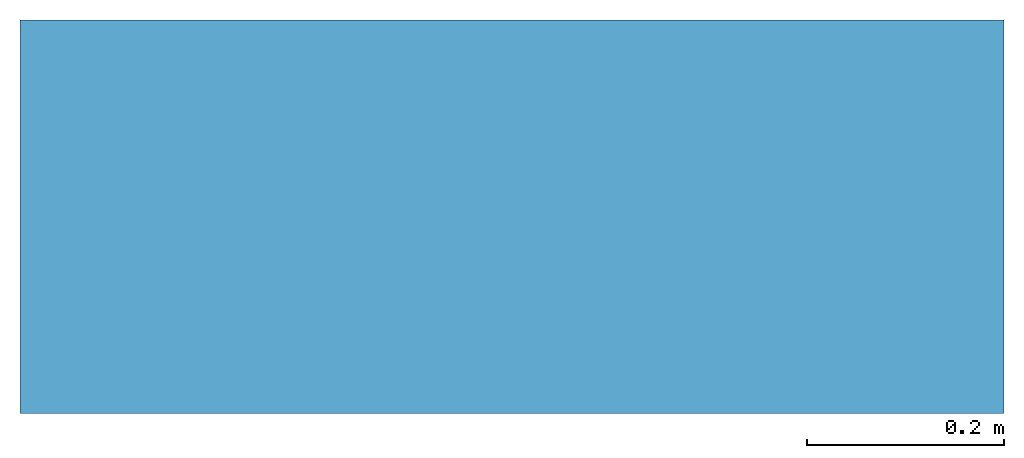
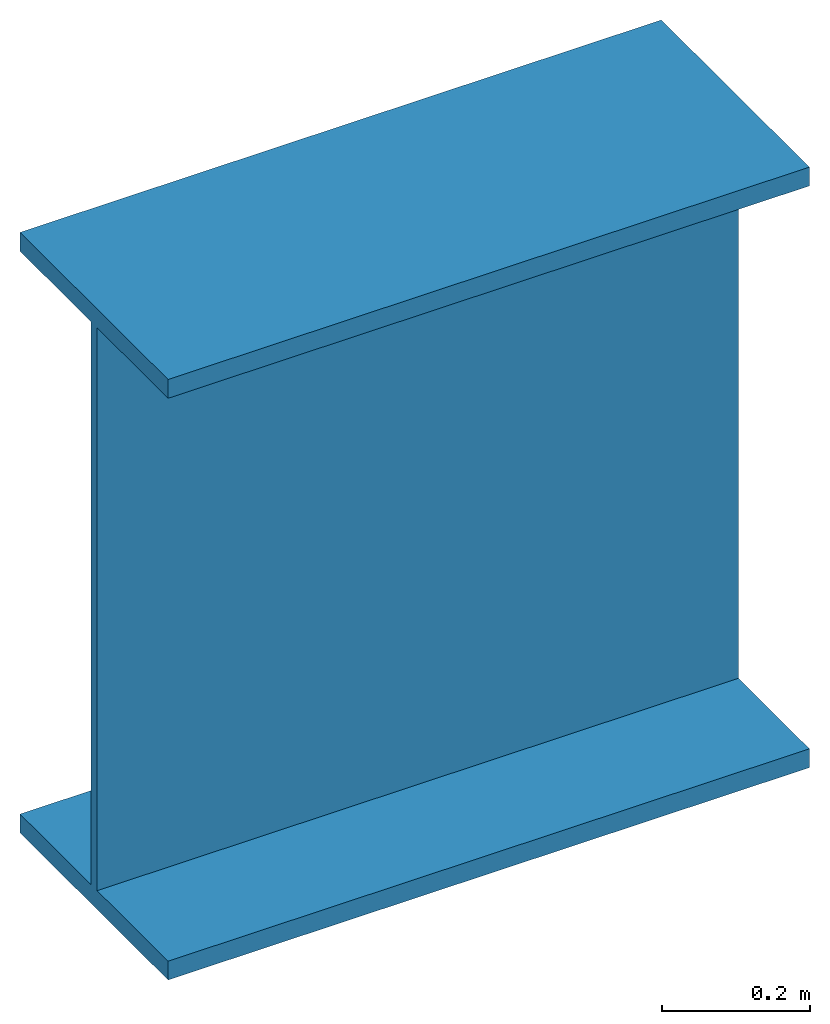
# Not in any storey: 1 beam.
"""IFC4 model written with IfcOpenShell, lengths in metres."""

from ifc_helpers import new_model, entity, si_unit, converted_unit, derived_unit, direction, frame, frame_2d, origin, place, context, subcontext, project, spatial, polyline, segment, composite_curve, i_section, outline, extrude, source, transform, mapped, material, material_profile, profile_set, profile_usage, type_object, type_shapes, element, save


model = new_model("IFC4")

# Units and contexts
model_context = context("Model", 3, precision=1e-05, world=origin(), true_north=direction((6.12303176911189e-17, 1.0)))
body_context = subcontext(model_context, "Body", "Model", "MODEL_VIEW")
ifc_project = project(units=[si_unit("LENGTHUNIT", "METRE"), si_unit("AREAUNIT", "SQUARE_METRE"), si_unit("VOLUMEUNIT", "CUBIC_METRE"), converted_unit("PLANEANGLEUNIT", "DEGREE", entity("IfcRatioMeasure", 0.0174532925199433), si_unit("PLANEANGLEUNIT", "RADIAN"), dimensions=[0, 0, 0, 0, 0, 0, 0]), si_unit("MASSUNIT", "GRAM", prefix="KILO"), derived_unit("MASSDENSITYUNIT", [(si_unit("MASSUNIT", "GRAM", prefix="KILO"), 1), (si_unit("LENGTHUNIT", "METRE"), -3)]), derived_unit("MOMENTOFINERTIAUNIT", [(si_unit("LENGTHUNIT", "METRE"), 4)]), si_unit("TIMEUNIT", "SECOND"), si_unit("FREQUENCYUNIT", "HERTZ"), si_unit("THERMODYNAMICTEMPERATUREUNIT", "DEGREE_CELSIUS"), derived_unit("THERMALTRANSMITTANCEUNIT", [(si_unit("MASSUNIT", "GRAM", prefix="KILO"), 1), (si_unit("THERMODYNAMICTEMPERATUREUNIT", "KELVIN"), -1), (si_unit("TIMEUNIT", "SECOND"), -3)]), derived_unit("VOLUMETRICFLOWRATEUNIT", [(si_unit("LENGTHUNIT", "METRE"), 3), (si_unit("TIMEUNIT", "SECOND"), -1)]), si_unit("ELECTRICCURRENTUNIT", "AMPERE"), si_unit("ELECTRICVOLTAGEUNIT", "VOLT"), si_unit("POWERUNIT", "WATT"), si_unit("FORCEUNIT", "NEWTON", prefix="KILO"), si_unit("ILLUMINANCEUNIT", "LUX"), si_unit("LUMINOUSFLUXUNIT", "LUMEN"), si_unit("LUMINOUSINTENSITYUNIT", "CANDELA"), derived_unit("USERDEFINED", [(si_unit("MASSUNIT", "GRAM", prefix="KILO"), -1), (si_unit("LENGTHUNIT", "METRE"), -2), (si_unit("TIMEUNIT", "SECOND"), 3), (si_unit("LUMINOUSFLUXUNIT", "LUMEN"), 1)]), derived_unit("LINEARVELOCITYUNIT", [(si_unit("LENGTHUNIT", "METRE"), 1), (si_unit("TIMEUNIT", "SECOND"), -1)]), si_unit("PRESSUREUNIT", "PASCAL"), derived_unit("USERDEFINED", [(si_unit("LENGTHUNIT", "METRE"), -2), (si_unit("MASSUNIT", "GRAM", prefix="KILO"), 1), (si_unit("TIMEUNIT", "SECOND"), -2)]), derived_unit("LINEARFORCEUNIT", [(si_unit("MASSUNIT", "GRAM", prefix="KILO"), 1), (si_unit("LENGTHUNIT", "METRE"), 1), (si_unit("TIMEUNIT", "SECOND"), -2), (si_unit("LENGTHUNIT", "METRE"), -1)]), derived_unit("PLANARFORCEUNIT", [(si_unit("MASSUNIT", "GRAM", prefix="KILO"), 1), (si_unit("LENGTHUNIT", "METRE"), 1), (si_unit("TIMEUNIT", "SECOND"), -2), (si_unit("LENGTHUNIT", "METRE"), -2)])], contexts=[model_context])

# Site
site_placement = place(None, origin())
site = spatial("IfcSite", under=ifc_project, at=site_placement, CompositionType="ELEMENT")

# Beam
ifc_material = material()
ifc_material_profile_1 = material_profile(ifc_material, outline(composite_curve([segment(polyline([(-0.200000000000002, -0.0309999999999954, 0.0), (-0.200000000000002, 0.0, 0.0)]), True, "CONTINUOUS"), segment(polyline([(-0.200000000000002, 0.0, 0.0), (0.199999999999997, 0.0, 0.0)]), True, "CONTINUOUS"), segment(polyline([(0.199999999999997, 0.0, 0.0), (0.199999999999997, -0.0309999999999949, 0.0)]), True, "CONTINUOUS"), segment(polyline([(0.199999999999997, -0.0309999999999949, 0.0), (0.00829999999999602, -0.0309999999999948, 0.0)]), True, "CONTINUOUS"), segment(polyline([(0.00829999999999602, -0.0309999999999948, 0.0), (0.00829999999999602, -0.958999999999991, 0.0)]), True, "CONTINUOUS"), segment(polyline([(0.00829999999999602, -0.958999999999991, 0.0), (0.199999999999994, -0.958999999999991, 0.0)]), True, "CONTINUOUS"), segment(polyline([(0.199999999999994, -0.958999999999991, 0.0), (0.199999999999994, -0.989999999999996, 0.0)]), True, "CONTINUOUS"), segment(polyline([(0.199999999999994, -0.989999999999996, 0.0), (-0.200000000000005, -0.989999999999996, 0.0)]), True, "CONTINUOUS"), segment(polyline([(-0.200000000000005, -0.989999999999996, 0.0), (-0.200000000000005, -0.958999999999996, 0.0)]), True, "CONTINUOUS"), segment(polyline([(-0.200000000000005, -0.958999999999996, 0.0), (-0.00830000000000258, -0.958999999999996, 0.0)]), True, "CONTINUOUS"), segment(polyline([(-0.00830000000000258, -0.958999999999996, 0.0), (-0.00830000000000258, -0.0309999999999954, 0.0)]), True, "CONTINUOUS"), segment(polyline([(-0.00830000000000258, -0.0309999999999954, 0.0), (-0.200000000000002, -0.0309999999999954, 0.0)]), True, "CONTINUOUS")], self_intersect=False), kind="CURVE"), Name="HL 1000A")
ifc_material_profile_2 = material_profile(ifc_material, outline(composite_curve([segment(polyline([(0.5, -0.200000000000002, 0.0), (0.5, -0.200000000000002, -0.0309999999999954)]), True, "CONTINUOUS"), segment(polyline([(0.5, -0.200000000000002, -0.0309999999999954), (0.5, -0.00830000000000231, -0.0309999999999954)]), True, "CONTINUOUS"), segment(polyline([(0.5, -0.00830000000000231, -0.0309999999999954), (0.5, -0.00830000000000231, -0.958999999999996)]), True, "CONTINUOUS"), segment(polyline([(0.5, -0.00830000000000231, -0.958999999999996), (0.5, -0.200000000000004, -0.958999999999996)]), True, "CONTINUOUS"), segment(polyline([(0.5, -0.200000000000004, -0.958999999999996), (0.5, -0.200000000000004, -0.989999999999996)]), True, "CONTINUOUS"), segment(polyline([(0.5, -0.200000000000004, -0.989999999999996), (0.5, 0.199999999999994, -0.989999999999996)]), True, "CONTINUOUS"), segment(polyline([(0.5, 0.199999999999994, -0.989999999999996), (0.5, 0.199999999999994, -0.958999999999991)]), True, "CONTINUOUS"), segment(polyline([(0.5, 0.199999999999994, -0.958999999999991), (0.5, 0.00829999999999629, -0.958999999999991)]), True, "CONTINUOUS"), segment(polyline([(0.5, 0.00829999999999629, -0.958999999999991), (0.5, 0.00829999999999629, -0.0309999999999948)]), True, "CONTINUOUS"), segment(polyline([(0.5, 0.00829999999999629, -0.0309999999999948), (0.5, 0.199999999999998, -0.0309999999999949)]), True, "CONTINUOUS"), segment(polyline([(0.5, 0.199999999999998, -0.0309999999999949), (0.5, 0.199999999999998, 0.0)]), True, "CONTINUOUS"), segment(polyline([(0.5, 0.199999999999998, 0.0), (0.5, -0.200000000000002, 0.0)]), True, "CONTINUOUS")], self_intersect=False), kind="CURVE"), Name="HL 1000A")
ifc_profile_set = profile_set([ifc_material_profile_1, ifc_material_profile_2], Name="HL 1000A")
ifc_profile_usage = profile_usage(ifc_profile_set, cardinal=8)
beam_type = type_object("IfcBeamType", Name="HL 1000A", PredefinedType="BEAM", material=ifc_profile_set)
shared_shape = source(origin(), body_context, "Body", "SweptSolid", [
    extrude(i_section(OverallWidth=0.399999999999999, OverallDepth=0.989999999999999, WebThickness=0.0165999999999986, FlangeThickness=0.0310000000000049, at=frame_2d((1.66533453693773e-15, -4.44089209850063e-16), x_axis=(0.0, 1.0))), frame((-0.5, 0.0, -0.494999999999995), z_axis=(1.0, 0.0, 0.0), x_axis=(0.0, 0.0, -1.0)), (0.0, 0.0, 1.0), 1.0),
])
type_shapes(beam_type, [shared_shape])
beam_placement = place(site_placement, frame((0.468202796647807, -1.57542478255666, 0.0)))
element("IfcBeam", 1, at=beam_placement, inside=site, type_object=beam_type, material=ifc_profile_usage, PredefinedType="BEAM", context=body_context, shape_type="MappedRepresentation", body=[
    mapped(shared_shape, transform((0.0, 0.0, 0.0), scale=1.0)),
])

save(model, "model.ifc")
